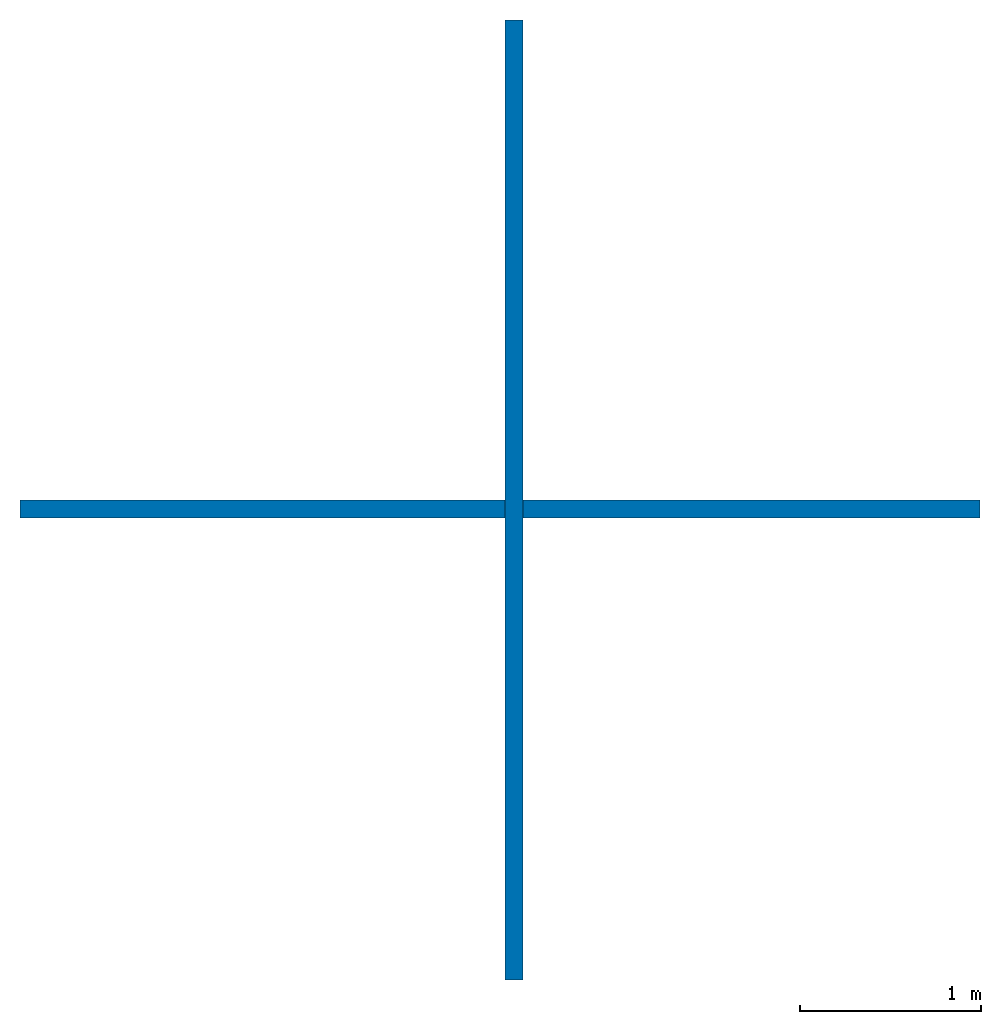
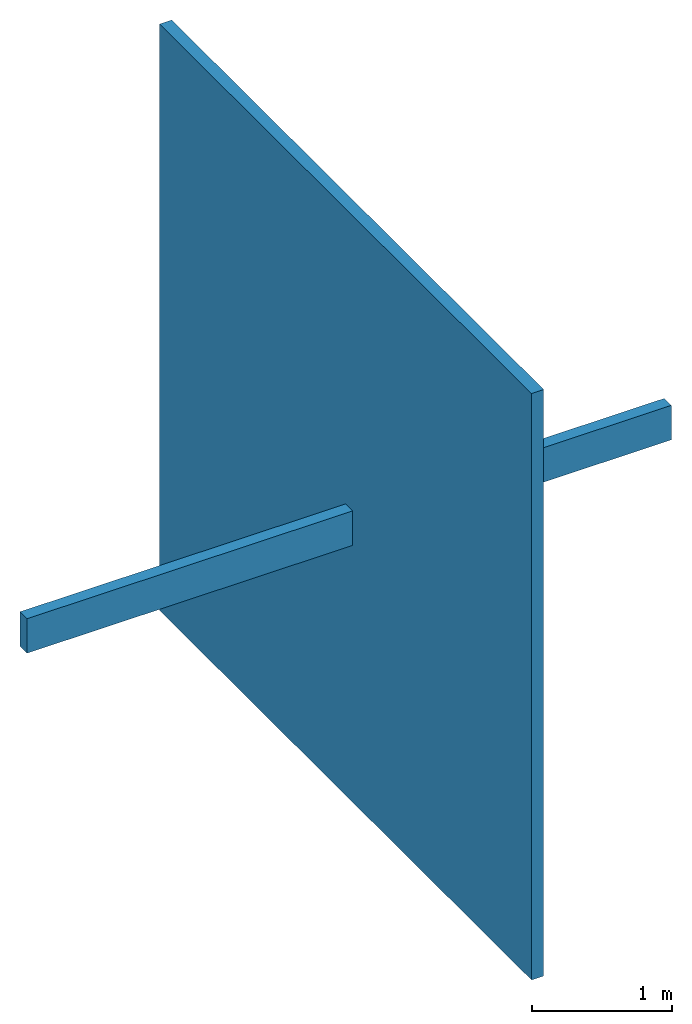
# One storey: 2 walls.
"""IFC4 building model written with IfcOpenShell, lengths in metres."""

from ifc_helpers import new_model, entity, si_unit, converted_unit, frame, origin_with_axes, origin_2d_with_axis, place, context, subcontext, project, spatial, indexed_curve, outline, extrude, material, layer, layer_set, layer_usage, type_object, element, save


model = new_model("IFC4")

# Units and contexts
model_context = context("Model", 3, precision=1e-05, world=origin_with_axes())
plan_context = context("Plan", 2, precision=1e-05, world=origin_2d_with_axis())
body_context = subcontext(model_context, "Body", "Model", "MODEL_VIEW")
ifc_project = project(units=[si_unit("LENGTHUNIT", "METRE"), converted_unit("PLANEANGLEUNIT", "degree", entity("IfcReal", 0.0174532925199433), si_unit("PLANEANGLEUNIT", "RADIAN"), dimensions=[0, 0, 0, 0, 0, 0, 0]), si_unit("AREAUNIT", "SQUARE_METRE"), si_unit("VOLUMEUNIT", "CUBIC_METRE")], contexts=[model_context, plan_context])

# Site, building, storey
site_placement = place(None, origin_with_axes())
site = spatial("IfcSite", under=ifc_project, at=site_placement)
building_placement = place(site_placement, origin_with_axes())
building = spatial("IfcBuilding", under=site, at=building_placement, Name="Building")
storey_placement = place(building_placement, origin_with_axes())
storey = spatial("IfcBuildingStorey", under=building, at=storey_placement, Name="Storey")

# Walls
ifc_material = material()
ifc_layer = layer(ifc_material, 0.1)
ifc_layer_set = layer_set([ifc_layer])
ifc_layer_usage_1 = layer_usage(ifc_layer_set, "AXIS2", "POSITIVE", 0.0)
wall_type = type_object("IfcWallType", PredefinedType="SOLIDWALL", material=ifc_layer_set)
wall_1_placement = place(storey_placement, frame((-5.40000009536743, 4.72083002023282e-07, 0.0), z_axis=(0.0, 0.0, 1.0), x_axis=(6.71544341912371e-07, 0.999999999999775, 0.0)))
element("IfcWall", 1, at=wall_1_placement, inside=storey, type_object=wall_type, material=ifc_layer_usage_1, Name="Wall", context=body_context, shape_type="SweptSolid", body=[
    extrude(outline(indexed_curve([(0.0, 0.0), (0.0, 0.1), (5.30000073415001, 0.1), (5.30000073415001, 0.0), (0.0, 0.0)], self_intersect=False)), origin_with_axes(), (0.0, 0.0, 1.0), 5.09999990463257),
])
ifc_layer_usage_2 = layer_usage(ifc_layer_set, "AXIS2", "POSITIVE", 0.0)
wall_2_placement = place(storey_placement, frame((-2.87801742553711, 2.65000081062317, 2.23302006721497), z_axis=(0.0, 0.0, 1.0), x_axis=(-0.999999999999803, 6.27832946520233e-07, 0.0)))
element("IfcWall", 2, at=wall_2_placement, inside=storey, type_object=wall_type, material=ifc_layer_usage_2, Name="Wall", context=body_context, shape_type="SweptSolid", body=[
    extrude(outline(indexed_curve([(0.0, 0.0), (0.0, 0.1), (5.30000109402732, 0.1), (5.30000109402732, 0.0), (0.0, 0.0)], self_intersect=False)), origin_with_axes(), (0.0, 0.0, 1.0), 0.300000011920929),
])

save(model, "model.ifc")
